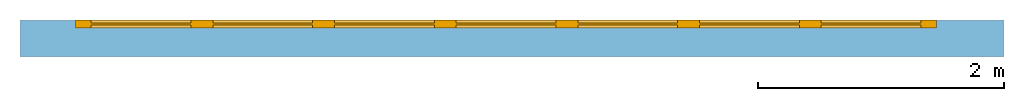
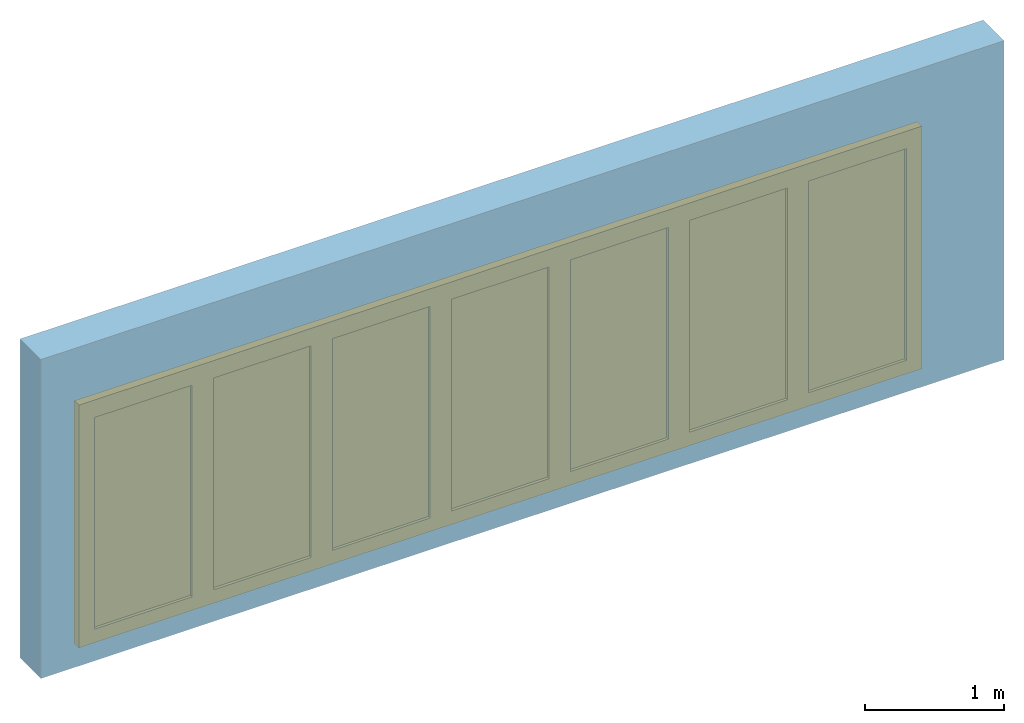
# One storey, part 2 of 2: 1 door, 1 opening, plus 1 element that does not belong to this part.
"""IFC2X3 building model written with IfcOpenShell, lengths in millimetres."""

from ifc_helpers import new_model, entity, si_unit, converted_unit, direction, frame, origin_with_axes, origin_2d_with_axis, place, context, subcontext, project, spatial, polyline, rectangle, outline, extrude, faceted_brep, source, transform, mapped, material, layer, layer_set, layer_usage, type_object, element, fill, save


model = new_model("IFC2X3")

# Units and contexts
model_context = context("Model", 3, precision=1e-05, world=origin_with_axes(), true_north=direction((0.0, 1.0)))
body_context = subcontext(model_context, "Body", "Model", "MODEL_VIEW")
ifc_project = project(units=[si_unit("LENGTHUNIT", "METRE", prefix="MILLI"), si_unit("AREAUNIT", "SQUARE_METRE"), si_unit("VOLUMEUNIT", "CUBIC_METRE"), converted_unit("PLANEANGLEUNIT", "DEGREE", entity("IfcPlaneAngleMeasure", 0.017453293), si_unit("PLANEANGLEUNIT", "RADIAN"), dimensions=[0, 0, 0, 0, 0, 0, 0]), si_unit("SOLIDANGLEUNIT", "STERADIAN"), si_unit("MASSUNIT", "GRAM"), si_unit("TIMEUNIT", "SECOND"), si_unit("THERMODYNAMICTEMPERATUREUNIT", "DEGREE_CELSIUS"), si_unit("LUMINOUSINTENSITYUNIT", "LUMEN")], contexts=[model_context])

# Site, building, storey
site_placement = place(None, origin_with_axes())
site = spatial("IfcSite", under=ifc_project, at=site_placement, CompositionType="ELEMENT")
building_placement = place(site_placement, origin_with_axes())
building = spatial("IfcBuilding", under=site, at=building_placement, CompositionType="ELEMENT")
storey_placement = place(building_placement, origin_with_axes())
storey = spatial("IfcBuildingStorey", under=building, at=storey_placement, Name="Ground Floor", CompositionType="ELEMENT", Elevation=0.0)

# Wall, opening, door
ifc_material_1 = material(Name="Masonry Block")
ifc_layer = layer(ifc_material_1, 300.0, ventilated="UNKNOWN")
ifc_layer_set = layer_set([ifc_layer], Name="Masonry Block 300")
ifc_layer_usage = layer_usage(ifc_layer_set, "AXIS2", "POSITIVE", 0.0)
wall_type = type_object("IfcWallType", Name="Masonry Block 300", PredefinedType="NOTDEFINED")
wall_placement = place(storey_placement, origin_with_axes())
wall = element("IfcWallStandardCase", 1, at=wall_placement, inside=storey, type_object=wall_type, material=ifc_layer_usage, Name="SW - 001", context=body_context, shape_type="SweptSolid", body=[
    extrude(outline(polyline([(0.0, 0.0), (7997.2943, 0.0), (7997.2943, 300.0), (0.0, 300.0), (0.0, 0.0)])), origin_with_axes(), (0.0, 0.0, 1.0), 2800.0),
])
opening_placement = place(wall_placement, frame((3950.3148, 0.0, 0.0), z_axis=(0.0, 0.0, 1.0), x_axis=(1.0, 0.0, 0.0)))
opening = element("IfcOpeningElement", 2, at=opening_placement, cuts=wall, Name="001", context=body_context, shape_type="SweptSolid", body=[
    extrude(rectangle(XDim=7000.0, YDim=2100.0, at=origin_2d_with_axis()), frame((0.0, 300.1, 1050.0), z_axis=(0.0, -1.0, 0.0), x_axis=(1.0, 0.0, 0.0)), (0.0, 0.0, 1.0), 0.2),
    extrude(rectangle(XDim=7000.0, YDim=2100.0, at=origin_2d_with_axis()), frame((0.0, 299.9, 1050.0), z_axis=(0.0, 1.0, 0.0), x_axis=(-1.0, 0.0, 0.0)), (0.0, 0.0, 1.0), 0.2),
])
ifc_material_2 = material(Name="Background")
door_style = type_object("IfcDoorStyle", ConstructionType="NOTDEFINED", OperationType="NOTDEFINED", ParameterTakesPrecedence=False, Sizeable=False)
shared_shape = source(origin_with_axes(), body_context, "Body", "Brep", [
    faceted_brep([(3500.0, 0.0, -30.0), (-3500.0, 0.0, -30.0), (-3500.0, 0.0, 0.0), (3500.0, 0.0, 0.0), (3500.0, -66.0, -30.0), (-3500.0, -66.0, -30.0), (-3500.0, -66.0, 0.0), (3500.0, -66.0, 0.0)], [[[0, 1, 2, 3]], [[1, 0, 4, 5]], [[2, 1, 5, 6]], [[3, 2, 6, 7]], [[0, 3, 7, 4]], [[5, 4, 7, 6]]]),
    faceted_brep([(3500.0, 0.0, 2036.0), (-3500.0, 0.0, 2036.0), (-3500.0, 0.0, 2100.0), (3500.0, 0.0, 2100.0), (3500.0, -66.0, 2036.0), (-3500.0, -66.0, 2036.0), (-3500.0, -66.0, 2100.0), (3500.0, -66.0, 2100.0)], [[[0, 1, 2, 3]], [[1, 0, 4, 5]], [[2, 1, 5, 6]], [[3, 2, 6, 7]], [[0, 3, 7, 4]], [[5, 4, 7, 6]]]),
    faceted_brep([(3500.0, 0.0, 0.0), (3460.0, 0.0, 0.0), (3460.0, 0.0, 2036.0), (3500.0, 0.0, 2036.0), (3500.0, -66.0, 0.0), (3460.0, -66.0, 0.0), (3460.0, -66.0, 2036.0), (3500.0, -66.0, 2036.0)], [[[0, 1, 2, 3]], [[1, 0, 4, 5]], [[2, 1, 5, 6]], [[3, 2, 6, 7]], [[0, 3, 7, 4]], [[5, 4, 7, 6]]]),
    faceted_brep([(-3460.0, 0.0, 0.0), (-3500.0, 0.0, 0.0), (-3500.0, 0.0, 2036.0), (-3460.0, 0.0, 2036.0), (-3460.0, -66.0, 0.0), (-3500.0, -66.0, 0.0), (-3500.0, -66.0, 2036.0), (-3460.0, -66.0, 2036.0)], [[[0, 1, 2, 3]], [[1, 0, 4, 5]], [[2, 1, 5, 6]], [[3, 2, 6, 7]], [[0, 3, 7, 4]], [[5, 4, 7, 6]]]),
    faceted_brep([(-3460.0, 0.0, 0.0), (-2471.4286, 0.0, 0.0), (-2471.4286, -66.0, 0.0), (-3460.0, -66.0, 0.0), (-3460.0, 0.0, 2036.0), (-2471.4286, 0.0, 2036.0), (-3371.5, 0.0, 88.5), (-2559.9286, 0.0, 88.5), (-2559.9286, 0.0, 1947.5), (-3371.5, 0.0, 1947.5), (-2471.4286, -66.0, 2036.0), (-3460.0, -66.0, 2036.0), (-3371.5, -66.0, 88.5), (-3371.5, -66.0, 1947.5), (-2559.9286, -66.0, 1947.5), (-2559.9286, -66.0, 88.5)], [[[0, 1, 2, 3]], [[0, 4, 5, 1], [6, 7, 8, 9]], [[1, 5, 10, 2]], [[3, 2, 10, 11], [12, 13, 14, 15]], [[4, 0, 3, 11]], [[5, 4, 11, 10]], [[7, 6, 12, 15]], [[8, 7, 15, 14]], [[9, 8, 14, 13]], [[6, 9, 13, 12]]]),
    faceted_brep([(-3371.5, -24.0, 88.5), (-2559.9286, -24.0, 88.5), (-2559.9286, -42.0, 88.5), (-3371.5, -42.0, 88.5), (-3371.5, -24.0, 1947.5), (-2559.9286, -24.0, 1947.5), (-2559.9286, -42.0, 1947.5), (-3371.5, -42.0, 1947.5)], [[[0, 1, 2, 3]], [[0, 4, 5, 1]], [[1, 5, 6, 2]], [[3, 2, 6, 7]], [[4, 0, 3, 7]], [[5, 4, 7, 6]]]),
    faceted_brep([(-2471.4286, 0.0, 0.0), (-1482.8571, 0.0, 0.0), (-1482.8571, -66.0, 0.0), (-2471.4286, -66.0, 0.0), (-2471.4286, 0.0, 2036.0), (-1482.8571, 0.0, 2036.0), (-2382.9286, 0.0, 88.5), (-1571.3571, 0.0, 88.5), (-1571.3571, 0.0, 1947.5), (-2382.9286, 0.0, 1947.5), (-1482.8571, -66.0, 2036.0), (-2471.4286, -66.0, 2036.0), (-2382.9286, -66.0, 88.5), (-2382.9286, -66.0, 1947.5), (-1571.3571, -66.0, 1947.5), (-1571.3571, -66.0, 88.5)], [[[0, 1, 2, 3]], [[0, 4, 5, 1], [6, 7, 8, 9]], [[1, 5, 10, 2]], [[3, 2, 10, 11], [12, 13, 14, 15]], [[4, 0, 3, 11]], [[5, 4, 11, 10]], [[7, 6, 12, 15]], [[8, 7, 15, 14]], [[9, 8, 14, 13]], [[6, 9, 13, 12]]]),
    faceted_brep([(-2382.9286, -24.0, 88.5), (-1571.3571, -24.0, 88.5), (-1571.3571, -42.0, 88.5), (-2382.9286, -42.0, 88.5), (-2382.9286, -24.0, 1947.5), (-1571.3571, -24.0, 1947.5), (-1571.3571, -42.0, 1947.5), (-2382.9286, -42.0, 1947.5)], [[[0, 1, 2, 3]], [[0, 4, 5, 1]], [[1, 5, 6, 2]], [[3, 2, 6, 7]], [[4, 0, 3, 7]], [[5, 4, 7, 6]]]),
    faceted_brep([(-1482.8571, 0.0, 0.0), (-494.28571, 0.0, 0.0), (-494.28571, -66.0, 0.0), (-1482.8571, -66.0, 0.0), (-1482.8571, 0.0, 2036.0), (-494.28571, 0.0, 2036.0), (-1394.3571, 0.0, 88.5), (-582.78571, 0.0, 88.5), (-582.78571, 0.0, 1947.5), (-1394.3571, 0.0, 1947.5), (-494.28571, -66.0, 2036.0), (-1482.8571, -66.0, 2036.0), (-1394.3571, -66.0, 88.5), (-1394.3571, -66.0, 1947.5), (-582.78571, -66.0, 1947.5), (-582.78571, -66.0, 88.5)], [[[0, 1, 2, 3]], [[0, 4, 5, 1], [6, 7, 8, 9]], [[1, 5, 10, 2]], [[3, 2, 10, 11], [12, 13, 14, 15]], [[4, 0, 3, 11]], [[5, 4, 11, 10]], [[7, 6, 12, 15]], [[8, 7, 15, 14]], [[9, 8, 14, 13]], [[6, 9, 13, 12]]]),
    faceted_brep([(-1394.3571, -24.0, 88.5), (-582.78571, -24.0, 88.5), (-582.78571, -42.0, 88.5), (-1394.3571, -42.0, 88.5), (-1394.3571, -24.0, 1947.5), (-582.78571, -24.0, 1947.5), (-582.78571, -42.0, 1947.5), (-1394.3571, -42.0, 1947.5)], [[[0, 1, 2, 3]], [[0, 4, 5, 1]], [[1, 5, 6, 2]], [[3, 2, 6, 7]], [[4, 0, 3, 7]], [[5, 4, 7, 6]]]),
    faceted_brep([(-494.28571, 0.0, 0.0), (494.28571, 0.0, 0.0), (494.28571, -66.0, 0.0), (-494.28571, -66.0, 0.0), (-494.28571, 0.0, 2036.0), (494.28571, 0.0, 2036.0), (-405.78571, 0.0, 88.5), (405.78571, 0.0, 88.5), (405.78571, 0.0, 1947.5), (-405.78571, 0.0, 1947.5), (494.28571, -66.0, 2036.0), (-494.28571, -66.0, 2036.0), (-405.78571, -66.0, 88.5), (-405.78571, -66.0, 1947.5), (405.78571, -66.0, 1947.5), (405.78571, -66.0, 88.5)], [[[0, 1, 2, 3]], [[0, 4, 5, 1], [6, 7, 8, 9]], [[1, 5, 10, 2]], [[3, 2, 10, 11], [12, 13, 14, 15]], [[4, 0, 3, 11]], [[5, 4, 11, 10]], [[7, 6, 12, 15]], [[8, 7, 15, 14]], [[9, 8, 14, 13]], [[6, 9, 13, 12]]]),
    faceted_brep([(-405.78571, -24.0, 88.5), (405.78571, -24.0, 88.5), (405.78571, -42.0, 88.5), (-405.78571, -42.0, 88.5), (-405.78571, -24.0, 1947.5), (405.78571, -24.0, 1947.5), (405.78571, -42.0, 1947.5), (-405.78571, -42.0, 1947.5)], [[[0, 1, 2, 3]], [[0, 4, 5, 1]], [[1, 5, 6, 2]], [[3, 2, 6, 7]], [[4, 0, 3, 7]], [[5, 4, 7, 6]]]),
    faceted_brep([(494.28571, 0.0, 0.0), (1482.8571, 0.0, 0.0), (1482.8571, -66.0, 0.0), (494.28571, -66.0, 0.0), (494.28571, 0.0, 2036.0), (1482.8571, 0.0, 2036.0), (582.78571, 0.0, 88.5), (1394.3571, 0.0, 88.5), (1394.3571, 0.0, 1947.5), (582.78571, 0.0, 1947.5), (1482.8571, -66.0, 2036.0), (494.28571, -66.0, 2036.0), (582.78571, -66.0, 88.5), (582.78571, -66.0, 1947.5), (1394.3571, -66.0, 1947.5), (1394.3571, -66.0, 88.5)], [[[0, 1, 2, 3]], [[0, 4, 5, 1], [6, 7, 8, 9]], [[1, 5, 10, 2]], [[3, 2, 10, 11], [12, 13, 14, 15]], [[4, 0, 3, 11]], [[5, 4, 11, 10]], [[7, 6, 12, 15]], [[8, 7, 15, 14]], [[9, 8, 14, 13]], [[6, 9, 13, 12]]]),
    faceted_brep([(582.78571, -24.0, 88.5), (1394.3571, -24.0, 88.5), (1394.3571, -42.0, 88.5), (582.78571, -42.0, 88.5), (582.78571, -24.0, 1947.5), (1394.3571, -24.0, 1947.5), (1394.3571, -42.0, 1947.5), (582.78571, -42.0, 1947.5)], [[[0, 1, 2, 3]], [[0, 4, 5, 1]], [[1, 5, 6, 2]], [[3, 2, 6, 7]], [[4, 0, 3, 7]], [[5, 4, 7, 6]]]),
    faceted_brep([(1482.8571, 0.0, 0.0), (2471.4286, 0.0, 0.0), (2471.4286, -66.0, 0.0), (1482.8571, -66.0, 0.0), (1482.8571, 0.0, 2036.0), (2471.4286, 0.0, 2036.0), (1571.3571, 0.0, 88.5), (2382.9286, 0.0, 88.5), (2382.9286, 0.0, 1947.5), (1571.3571, 0.0, 1947.5), (2471.4286, -66.0, 2036.0), (1482.8571, -66.0, 2036.0), (1571.3571, -66.0, 88.5), (1571.3571, -66.0, 1947.5), (2382.9286, -66.0, 1947.5), (2382.9286, -66.0, 88.5)], [[[0, 1, 2, 3]], [[0, 4, 5, 1], [6, 7, 8, 9]], [[1, 5, 10, 2]], [[3, 2, 10, 11], [12, 13, 14, 15]], [[4, 0, 3, 11]], [[5, 4, 11, 10]], [[7, 6, 12, 15]], [[8, 7, 15, 14]], [[9, 8, 14, 13]], [[6, 9, 13, 12]]]),
    faceted_brep([(1571.3571, -24.0, 88.5), (2382.9286, -24.0, 88.5), (2382.9286, -42.0, 88.5), (1571.3571, -42.0, 88.5), (1571.3571, -24.0, 1947.5), (2382.9286, -24.0, 1947.5), (2382.9286, -42.0, 1947.5), (1571.3571, -42.0, 1947.5)], [[[0, 1, 2, 3]], [[0, 4, 5, 1]], [[1, 5, 6, 2]], [[3, 2, 6, 7]], [[4, 0, 3, 7]], [[5, 4, 7, 6]]]),
    faceted_brep([(2471.4286, 0.0, 0.0), (3460.0, 0.0, 0.0), (3460.0, -66.0, 0.0), (2471.4286, -66.0, 0.0), (2471.4286, 0.0, 2036.0), (3460.0, 0.0, 2036.0), (2559.9286, 0.0, 88.5), (3371.5, 0.0, 88.5), (3371.5, 0.0, 1947.5), (2559.9286, 0.0, 1947.5), (3460.0, -66.0, 2036.0), (2471.4286, -66.0, 2036.0), (2559.9286, -66.0, 88.5), (2559.9286, -66.0, 1947.5), (3371.5, -66.0, 1947.5), (3371.5, -66.0, 88.5)], [[[0, 1, 2, 3]], [[0, 4, 5, 1], [6, 7, 8, 9]], [[1, 5, 10, 2]], [[3, 2, 10, 11], [12, 13, 14, 15]], [[4, 0, 3, 11]], [[5, 4, 11, 10]], [[7, 6, 12, 15]], [[8, 7, 15, 14]], [[9, 8, 14, 13]], [[6, 9, 13, 12]]]),
    faceted_brep([(2559.9286, -24.0, 88.5), (3371.5, -24.0, 88.5), (3371.5, -42.0, 88.5), (2559.9286, -42.0, 88.5), (2559.9286, -24.0, 1947.5), (3371.5, -24.0, 1947.5), (3371.5, -42.0, 1947.5), (2559.9286, -42.0, 1947.5)], [[[0, 1, 2, 3]], [[0, 4, 5, 1]], [[1, 5, 6, 2]], [[3, 2, 6, 7]], [[4, 0, 3, 7]], [[5, 4, 7, 6]]]),
])
door_placement = place(opening_placement, frame((-3500.0, 0.0, 0.0), z_axis=(0.0, 0.0, 1.0), x_axis=(1.0, 0.0, 0.0)))
door = element("IfcDoor", 3, at=door_placement, inside=storey, type_object=door_style, material=ifc_material_2, Name="001", OverallHeight=2100.0, OverallWidth=7000.0, context=body_context, shape_type="MappedRepresentation", body=[
    mapped(shared_shape, transform((3500.0, 300.0, 0.0))),
])
fill(opening, door)

save(model, "model.ifc")
